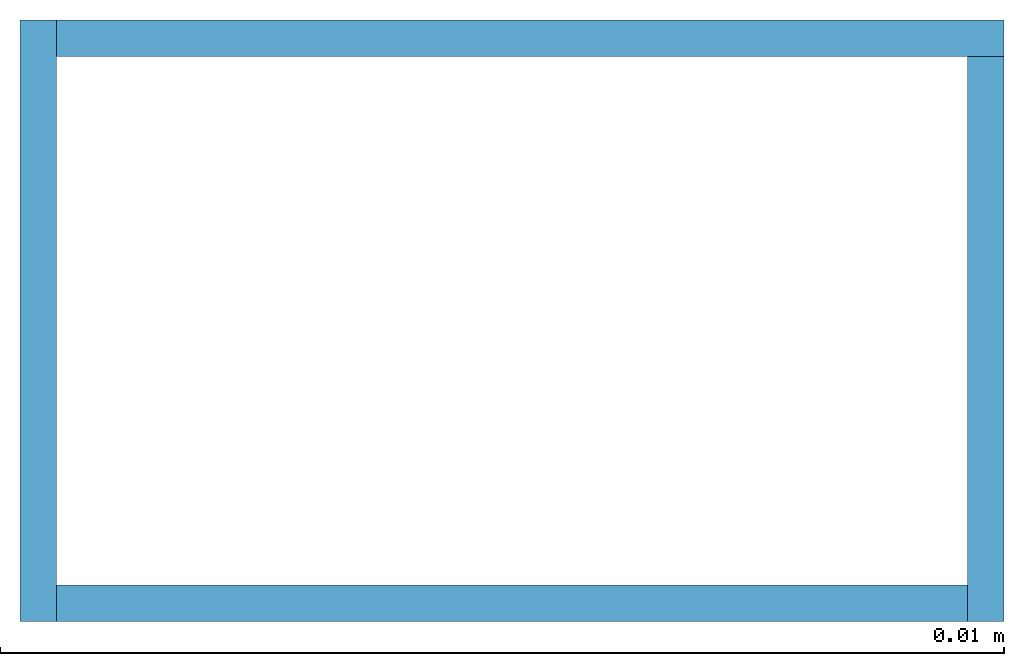
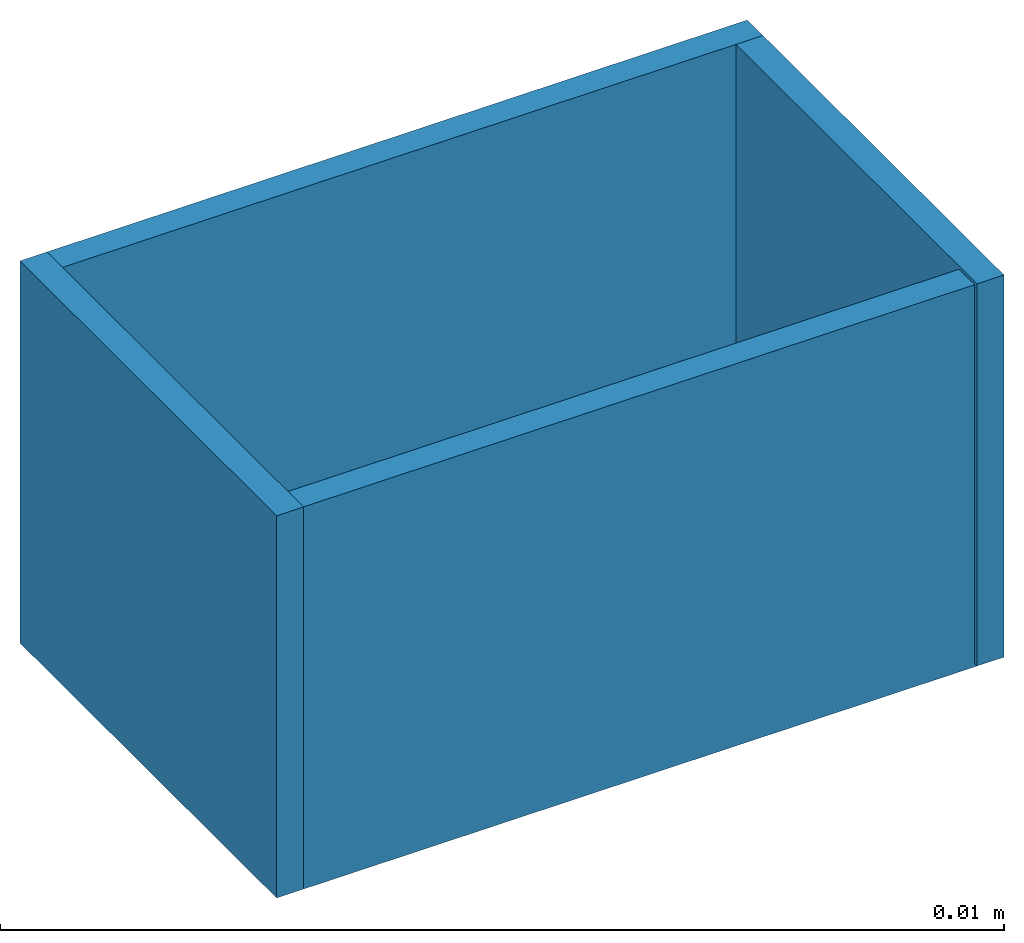
# One storey: 4 walls.
"""IFC4 building model written with IfcOpenShell, lengths in millimetres."""

from ifc_helpers import new_model, si_unit, frame_2d, origin_with_axes, place, context, project, spatial, polyline, outline, extrude, element, save


model = new_model("IFC4")

# Units and contexts
model_context = context("Model", 3, precision=1e-05, world=origin_with_axes())
plan_context = context("Plan", 2, precision=1e-05, world=frame_2d((0.0, 0.0, 0.0), x_axis=(1.0, 0.0, 0.0)))
ifc_project = project(units=[si_unit("AREAUNIT", "SQUARE_METRE"), si_unit("VOLUMEUNIT", "CUBIC_METRE"), si_unit("LENGTHUNIT", "METRE", prefix="MILLI")], contexts=[model_context, plan_context])

# Site, building, storey
site_placement = place(None, origin_with_axes())
site = spatial("IfcSite", under=ifc_project, at=site_placement)
building_placement = place(site_placement, origin_with_axes())
building = spatial("IfcBuilding", under=site, at=building_placement)
storey_placement = place(building_placement, origin_with_axes())
storey = spatial("IfcBuildingStorey", under=building, at=storey_placement, Name="Level 0", Elevation=0.0)

# Walls
placement = place(storey_placement, origin_with_axes())
element("IfcWall", 1, at=placement, inside=storey, PredefinedType="NOTDEFINED", context=model_context, shape_type="SweptSolid", body=[
    extrude(outline(polyline([(0.0, -0.1, 0.0), (5.0, -0.1, 0.0), (5.0, 0.1, 0.0), (0.0, 0.1, 0.0), (0.0, -0.1, 0.0)])), origin_with_axes(), (0.0, 0.0, 1.0), 3.0),
])
element("IfcWall", 2, at=placement, inside=storey, PredefinedType="NOTDEFINED", context=model_context, shape_type="SweptSolid", body=[
    extrude(outline(polyline([(5.0, -0.1, 0.0), (5.2, -0.1, 0.0), (5.2, 3.0, 0.0), (5.0, 3.0, 0.0), (5.0, -0.1, 0.0)])), origin_with_axes(), (0.0, 0.0, 1.0), 3.0),
])
element("IfcWall", 3, at=placement, inside=storey, PredefinedType="NOTDEFINED", context=model_context, shape_type="SweptSolid", body=[
    extrude(outline(polyline([(5.2, 3.0, 0.0), (5.2, 3.2, 0.0), (0.0, 3.2, 0.0), (0.0, 3.0, 0.0), (5.2, 3.0, 0.0)])), origin_with_axes(), (0.0, 0.0, 1.0), 3.0),
])
element("IfcWall", 4, at=placement, inside=storey, PredefinedType="NOTDEFINED", context=model_context, shape_type="SweptSolid", body=[
    extrude(outline(polyline([(0.0, 3.2, 0.0), (-0.2, 3.2, 0.0), (-0.2, -0.1, 0.0), (0.0, -0.1, 0.0), (0.0, 3.2, 0.0)])), origin_with_axes(), (0.0, 0.0, 1.0), 3.0),
])

save(model, "model.ifc")
